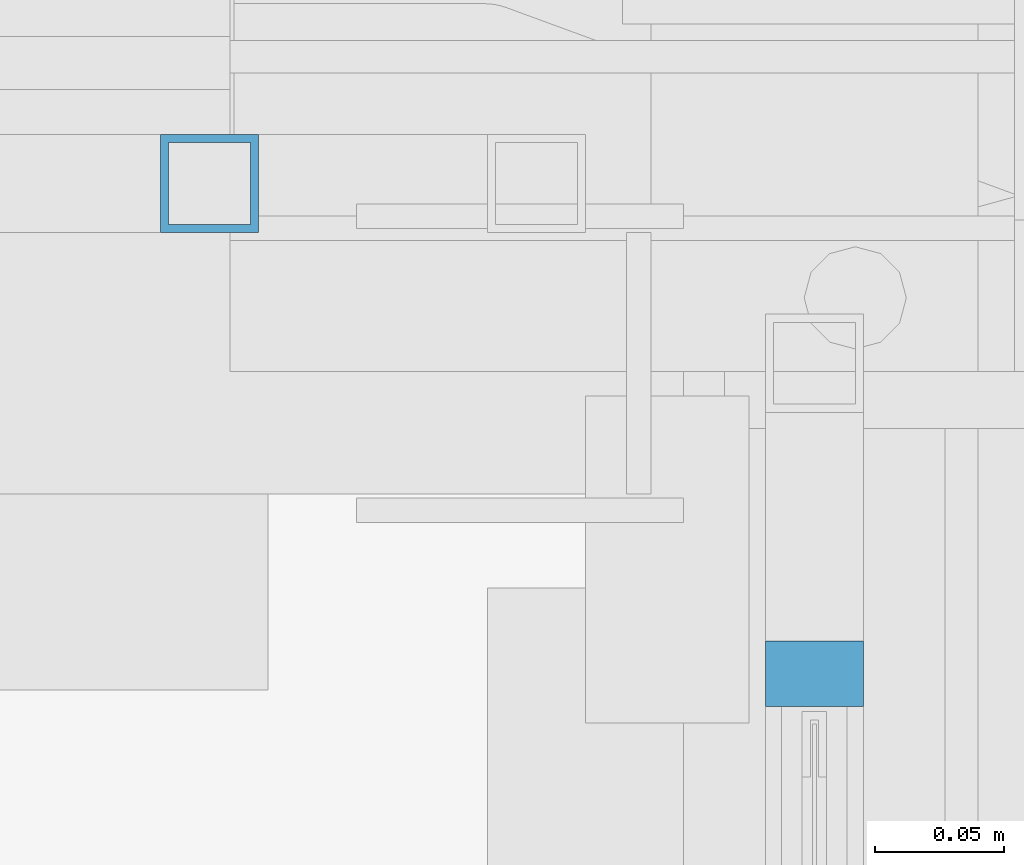
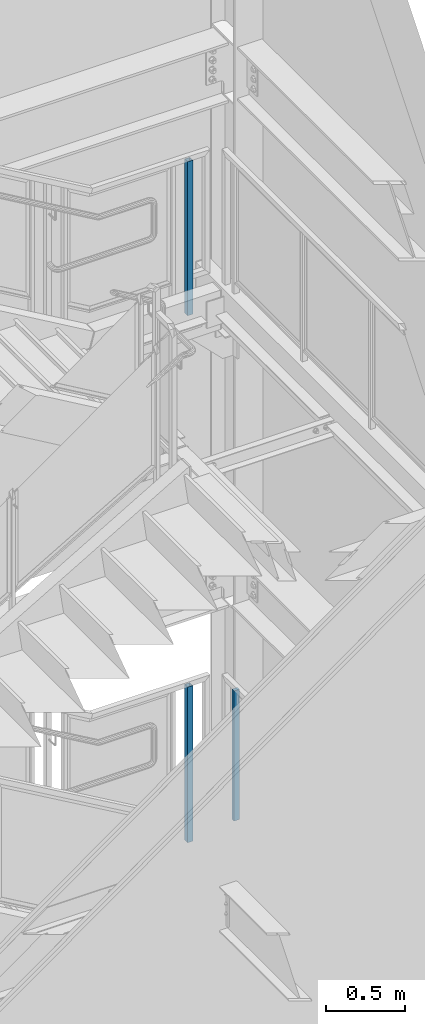
# One storey, part 801 of 1179: 3 members, 3 elements without a shape of their own.
"""IFC2X3 building model written with IfcOpenShell, lengths in millimetres."""

from ifc_helpers import new_model, si_unit, frame, origin_with_axes, place, context, subcontext, project, spatial, faceted_brep, material, type_object, element, aggregate, save


model = new_model("IFC2X3")

# Units and contexts
model_context = context("Model", 3, precision=1e-05, world=origin_with_axes())
body_context = subcontext(model_context, "Body", "Model", "MODEL_VIEW")
ifc_project = project(units=[si_unit("LENGTHUNIT", "METRE", prefix="MILLI"), si_unit("AREAUNIT", "SQUARE_METRE"), si_unit("VOLUMEUNIT", "CUBIC_METRE"), si_unit("MASSUNIT", "GRAM", prefix="KILO"), si_unit("TIMEUNIT", "SECOND"), si_unit("PLANEANGLEUNIT", "RADIAN"), si_unit("SOLIDANGLEUNIT", "STERADIAN"), si_unit("THERMODYNAMICTEMPERATUREUNIT", "DEGREE_CELSIUS"), si_unit("LUMINOUSINTENSITYUNIT", "LUMEN")], contexts=[model_context])

# Site, building, storey
site_placement = place(None, origin_with_axes())
site = spatial("IfcSite", under=ifc_project, at=site_placement, CompositionType="ELEMENT")
building_placement = place(site_placement, origin_with_axes())
building = spatial("IfcBuilding", under=site, at=building_placement, Name="Undefined", CompositionType="ELEMENT")
storey_placement = place(building_placement, origin_with_axes())
storey = spatial("IfcBuildingStorey", under=building, at=storey_placement, Name="Undefined", CompositionType="ELEMENT", Elevation=0.0)

# Assembly, member
assembly_1_placement = place(storey_placement, origin_with_axes())
assembly_1 = element("IfcElementAssembly", 1, at=assembly_1_placement, inside=storey, Name="GUARDRAIL", AssemblyPlace="NOTDEFINED", PredefinedType="RIGID_FRAME")
ifc_material_1 = material(Name="STEEL/A36")
member_type_1 = type_object("IfcMemberType", PredefinedType="NOTDEFINED")
member_1_placement = place(assembly_1_placement, frame((24114.1250004143, 40874.9500000007, 2155.825), z_axis=(-1.0, 0.0, 0.0), x_axis=(0.0, 0.0, 1.0)))
member_1 = element("IfcMember", 2, at=member_1_placement, type_object=member_type_1, material=ifc_material_1, Name="POST", context=body_context, shape_type="Brep", body=[
    faceted_brep([(0.0, 12.7000000000007, -19.0500000000029), (0.0, 12.7000000000007, 19.0500000000029), (1009.65000040151, 12.6999999999971, 19.0499999999993), (1009.65000040151, 12.6999999999971, -19.0499999999993), (0.0, -12.7000000000007, 19.0500000000029), (1009.65000040151, -12.6999999999971, 19.0499999999993), (0.0, -12.7000000000007, -19.0500000000029), (1009.65000040151, -12.6999999999971, -19.0499999999993)], [[[0, 1, 2, 3]], [[1, 4, 5, 2]], [[4, 6, 7, 5]], [[6, 0, 3, 7]], [[5, 7, 3, 2]], [[6, 4, 1, 0]]]),
])
aggregate(assembly_1, [member_1])

assembly_2_placement = place(storey_placement, origin_with_axes())
assembly_2 = element("IfcElementAssembly", 3, at=assembly_2_placement, inside=storey, Name="GUARDRAIL", AssemblyPlace="NOTDEFINED", PredefinedType="RIGID_FRAME")
ifc_material_2 = material()
member_type_2 = type_object("IfcMemberType", Name="HSS1-1/2X1-1/2X1/8", PredefinedType="NOTDEFINED")
member_2_placement = place(assembly_2_placement, frame((23879.1750021424, 41065.4499993604, 1952.62499991228), z_axis=(-1.0, 0.0, 0.0), x_axis=(0.0, 0.0, 1.0)))
member_2 = element("IfcMember", 4, at=member_2_placement, type_object=member_type_2, material=ifc_material_2, Name="POST", ObjectType="HSS1-1/2X1-1/2X1/8", context=body_context, shape_type="Brep", body=[
    faceted_brep([(6.35000000000014, 15.874999282998, -15.8749992830017), (6.35000000000014, -15.874999282998, -15.8749992830017), (1212.8500000288, -15.874999282998, -15.8749992830017), (1212.8500000288, 15.874999282998, -15.8749992830017), (6.35000000000014, -15.874999282998, 15.8749992830017), (1212.8500000288, -15.874999282998, 15.8749992830017), (6.35000000000014, 15.874999282998, 15.8749992830017), (1212.8500000288, 15.874999282998, 15.8749992830017), (6.35000000000014, 19.0499992350015, -19.0499992350015), (6.35000000000014, 19.0499992350015, 19.0499992350015), (1212.8500000288, 19.0499992350015, 19.0499992350015), (1212.8500000288, 19.0499992350015, -19.0499992350015), (6.35000000000014, -19.0499992350015, 19.0499992350015), (1212.8500000288, -19.0499992350015, 19.0499992350015), (6.35000000000014, -19.0499992350015, -19.0499992350015), (1212.8500000288, -19.0499992350015, -19.0499992350015)], [[[0, 1, 2, 3]], [[1, 4, 5, 2]], [[4, 6, 7, 5]], [[6, 0, 3, 7]], [[8, 9, 10, 11]], [[9, 12, 13, 10]], [[12, 14, 15, 13]], [[14, 8, 11, 15]], [[13, 15, 11, 10], [5, 7, 3, 2]], [[14, 12, 9, 8], [6, 4, 1, 0]]]),
])
aggregate(assembly_2, [member_2])

assembly_3_placement = place(storey_placement, origin_with_axes())
assembly_3 = element("IfcElementAssembly", 5, at=assembly_3_placement, inside=storey, Name="GUARDRAIL", AssemblyPlace="NOTDEFINED", PredefinedType="RIGID_FRAME")
member_3_placement = place(assembly_3_placement, frame((23879.17500153, 41065.449999238, 6038.85000001208), z_axis=(0.0, -1.0, 0.0), x_axis=(0.0, 0.0, 1.0)))
member_3 = element("IfcMember", 6, at=member_3_placement, type_object=member_type_2, material=ifc_material_2, Name="POST", ObjectType="HSS1-1/2X1-1/2X1/8", context=body_context, shape_type="Brep", body=[
    faceted_brep([(1200.14999917657, -19.0499992350015, 19.0499999979947), (1200.14999917657, -19.0499992350015, -19.0499992350015), (1200.14999917657, 19.0499992350015, -19.0499992350015), (1200.14999917657, 19.0499992350015, 19.0499992350015), (1200.14999917657, -15.8749992830017, 15.874999282998), (1200.14999917657, 15.8749992830017, 15.874999282998), (1200.14999917657, 15.8749992830017, -15.874999282998), (1200.14999917657, -15.8749992830017, -15.874999282998), (6.35000000000014, 19.0499992350015, 19.0499992350015), (6.35000000000014, -19.0499992350015, 19.0499992350015), (6.35000000000014, -19.0499992350015, -19.0499992350015), (6.35000000000014, 19.0499992350015, -19.0499992350015), (6.35000000000014, 15.874999282998, 15.8749992830017), (6.35000000000014, -15.874999282998, 15.8749992830017), (6.35000000000014, -15.874999282998, -15.8749992830017), (6.35000000000014, 15.874999282998, -15.8749992830017)], [[[0, 1, 2, 3], [4, 5, 6, 7]], [[8, 9, 0, 3]], [[10, 11, 2, 1]], [[9, 10, 1, 0]], [[11, 8, 3, 2]], [[10, 9, 8, 11], [12, 13, 14, 15]], [[14, 13, 4, 7]], [[15, 14, 7, 6]], [[12, 15, 6, 5]], [[13, 12, 5, 4]]]),
])
aggregate(assembly_3, [member_3])

save(model, "model.ifc")
